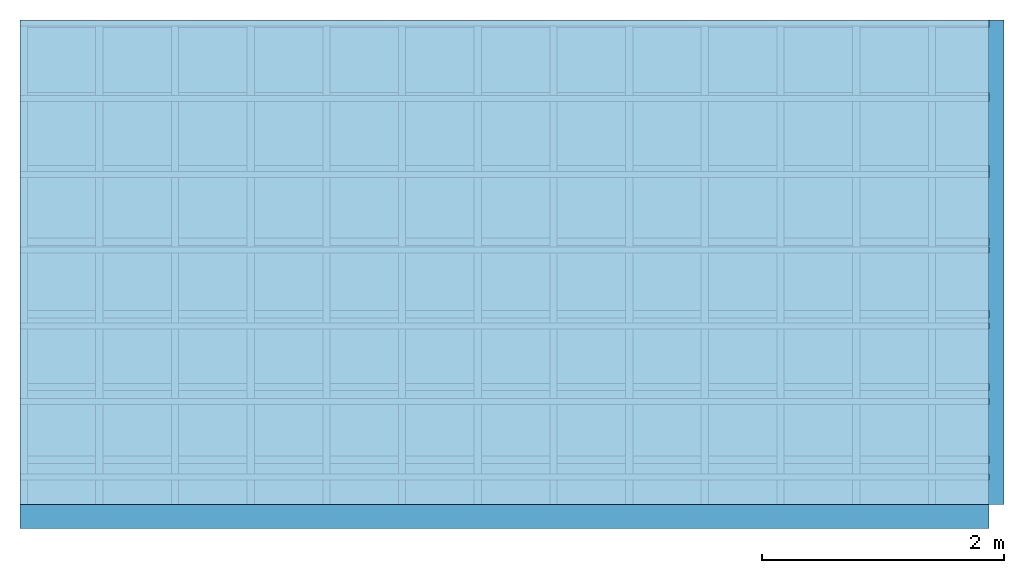
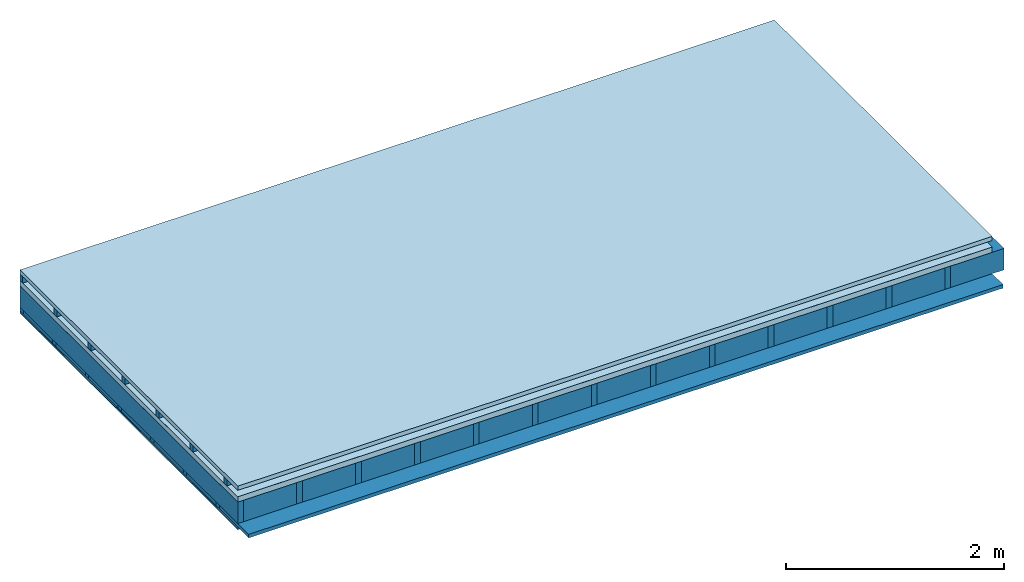
# One storey: 5 members, 5 plates, 1 element without a shape of its own.
"""IFC4 building model written with IfcOpenShell, lengths in metres."""

from ifc_helpers import new_model, si_unit, derived_unit, direction, frame, frame_2d, origin, origin_with_axes, place, context, project, spatial, rectangle, extrude, material, layer, layer_set, type_object, element, aggregate, save


model = new_model("IFC4")

# Units and contexts
plan_context = context("Plan", 3, precision=1e-05, world=origin(), true_north=direction((0.0, 1.0)))
model_context = context("Model", 3, precision=1e-05, world=origin(), true_north=direction((0.0, 1.0)))
ifc_project = project(units=[si_unit("LENGTHUNIT", "METRE"), derived_unit("SOUNDPRESSUREUNIT", [(si_unit("PRESSUREUNIT", "PASCAL", prefix="MICRO"), 0)]), si_unit("ENERGYUNIT", "JOULE", prefix="MEGA"), si_unit("MASSUNIT", "GRAM", prefix="KILO"), derived_unit("THERMALTRANSMITTANCEUNIT", [(si_unit("POWERUNIT", "WATT"), 1), (si_unit("AREAUNIT", "SQUARE_METRE"), -1), (si_unit("THERMODYNAMICTEMPERATUREUNIT", "KELVIN"), -1)]), derived_unit("AREADENSITYUNIT", [(si_unit("MASSUNIT", "GRAM", prefix="KILO"), 1), (si_unit("AREAUNIT", "SQUARE_METRE"), -1)]), derived_unit("USERDEFINED", [(si_unit("ENERGYUNIT", "JOULE", prefix="MEGA"), 1), (si_unit("AREAUNIT", "SQUARE_METRE"), -1)])], contexts=[plan_context, model_context])

# Site, building, storey
site = spatial("IfcSite", under=ifc_project)
building_placement = place(None, origin())
building = spatial("IfcBuilding", under=site, at=building_placement)
storey_placement = place(building_placement, origin())
storey = spatial("IfcBuildingStorey", under=building, at=storey_placement)

# Slab, members, plates
ifc_material_1 = material(Name="Roof tiles", Category="03.015")
ifc_layer_1 = layer(ifc_material_1, 0.047, Name="Roofing")
ifc_layer_2 = layer(None, 0.072, Name="Battens / profiles")
ifc_material_2 = material(Name="Roofing underlay", Category="09.008")
ifc_layer_3 = layer(ifc_material_2, 0.00018, Name="Under the roof")
ifc_material_3 = material(Category="10.009")
ifc_layer_4 = layer(ifc_material_3, 0.06, Name="Exterior insulation layer 1")
ifc_material_4 = material(Name="no composite action")
ifc_layer_5 = layer(ifc_material_4, 0.0, Name="Bond")
ifc_layer_6 = layer(None, 0.24, Name="Supporting structure")
ifc_material_5 = material(Name="of the art")
ifc_layer_7 = layer(ifc_material_5, 0.0, Name="Bond")
ifc_layer_8 = layer(None, 0.04, Name="Battens / profiles")
ifc_material_6 = material(Name="Plasterboard type A", Category="03.008")
ifc_layer_9 = layer(ifc_material_6, 0.015, Name="Covering below 1st layer")
ifc_layer_10 = layer(ifc_material_6, 0.015, Name="Covering below 2nd layer")
ifc_material_7 = material(Name="joints", Category="04.017")
ifc_layer_11 = layer(ifc_material_7, 0.0, Name="Surface below")
ifc_layer_set = layer_set([ifc_layer_1, ifc_layer_2, ifc_layer_3, ifc_layer_4, ifc_layer_5, ifc_layer_6, ifc_layer_7, ifc_layer_8, ifc_layer_9, ifc_layer_10, ifc_layer_11])
slab_type = type_object("IfcSlabType", Name="E0125", PredefinedType="NOTDEFINED", material=ifc_layer_set)
slab_placement = place(None, frame((0.0, 0.0, 0.0), z_axis=(0.0, 0.0, -1.0), x_axis=(1.0, 0.0, 0.0)))
slab = element("IfcSlab", 1, at=slab_placement, inside=storey, type_object=slab_type, material=ifc_layer_set, Name="Slab #1")
ifc_material_8 = material()
member_1_placement = place(slab_placement, origin())
member_1 = element("IfcMember", 2, at=member_1_placement, material=ifc_material_8, Name="Battens / profiles", context=plan_context, shape_type="SweptSolid", body=[
    extrude(rectangle(XDim=0.05, YDim=0.072, at=frame_2d((0.025, 0.036), x_axis=(1.0, 0.0))), frame((0.0, 0.0, 0.047), z_axis=(1.0, 0.0, 0.0), x_axis=(0.0, 1.0, 0.0)), (0.0, 0.0, 1.0), 8.0),
    extrude(rectangle(XDim=0.05, YDim=0.072, at=frame_2d((0.025, 0.036), x_axis=(1.0, 0.0))), frame((0.0, 0.625, 0.047), z_axis=(1.0, 0.0, 0.0), x_axis=(0.0, 1.0, 0.0)), (0.0, 0.0, 1.0), 8.0),
    extrude(rectangle(XDim=0.05, YDim=0.072, at=frame_2d((0.025, 0.036), x_axis=(1.0, 0.0))), frame((0.0, 1.25, 0.047), z_axis=(1.0, 0.0, 0.0), x_axis=(0.0, 1.0, 0.0)), (0.0, 0.0, 1.0), 8.0),
    extrude(rectangle(XDim=0.05, YDim=0.072, at=frame_2d((0.025, 0.036), x_axis=(1.0, 0.0))), frame((0.0, 1.875, 0.047), z_axis=(1.0, 0.0, 0.0), x_axis=(0.0, 1.0, 0.0)), (0.0, 0.0, 1.0), 8.0),
    extrude(rectangle(XDim=0.05, YDim=0.072, at=frame_2d((0.025, 0.036), x_axis=(1.0, 0.0))), frame((0.0, 2.5, 0.047), z_axis=(1.0, 0.0, 0.0), x_axis=(0.0, 1.0, 0.0)), (0.0, 0.0, 1.0), 8.0),
    extrude(rectangle(XDim=0.05, YDim=0.072, at=frame_2d((0.025, 0.036), x_axis=(1.0, 0.0))), frame((0.0, 3.125, 0.047), z_axis=(1.0, 0.0, 0.0), x_axis=(0.0, 1.0, 0.0)), (0.0, 0.0, 1.0), 8.0),
    extrude(rectangle(XDim=0.05, YDim=0.072, at=frame_2d((0.025, 0.036), x_axis=(1.0, 0.0))), frame((0.0, 3.75, 0.047), z_axis=(1.0, 0.0, 0.0), x_axis=(0.0, 1.0, 0.0)), (0.0, 0.0, 1.0), 8.0),
])
ifc_material_9 = material()
member_2_placement = place(slab_placement, origin())
member_2 = element("IfcMember", 3, at=member_2_placement, material=ifc_material_9, Name="Supporting structure", context=plan_context, shape_type="SweptSolid", body=[
    extrude(rectangle(XDim=0.06, YDim=0.24, at=frame_2d((0.03, 0.12), x_axis=(1.0, 0.0))), frame((0.0, 4.0, 0.17918), z_axis=(0.0, -1.0, 0.0), x_axis=(1.0, 0.0, 0.0)), (0.0, 0.0, 1.0), 4.0),
    extrude(rectangle(XDim=0.06, YDim=0.24, at=frame_2d((0.03, 0.12), x_axis=(1.0, 0.0))), frame((0.625, 4.0, 0.17918), z_axis=(0.0, -1.0, 0.0), x_axis=(1.0, 0.0, 0.0)), (0.0, 0.0, 1.0), 4.0),
    extrude(rectangle(XDim=0.06, YDim=0.24, at=frame_2d((0.03, 0.12), x_axis=(1.0, 0.0))), frame((1.25, 4.0, 0.17918), z_axis=(0.0, -1.0, 0.0), x_axis=(1.0, 0.0, 0.0)), (0.0, 0.0, 1.0), 4.0),
    extrude(rectangle(XDim=0.06, YDim=0.24, at=frame_2d((0.03, 0.12), x_axis=(1.0, 0.0))), frame((1.875, 4.0, 0.17918), z_axis=(0.0, -1.0, 0.0), x_axis=(1.0, 0.0, 0.0)), (0.0, 0.0, 1.0), 4.0),
    extrude(rectangle(XDim=0.06, YDim=0.24, at=frame_2d((0.03, 0.12), x_axis=(1.0, 0.0))), frame((2.5, 4.0, 0.17918), z_axis=(0.0, -1.0, 0.0), x_axis=(1.0, 0.0, 0.0)), (0.0, 0.0, 1.0), 4.0),
    extrude(rectangle(XDim=0.06, YDim=0.24, at=frame_2d((0.03, 0.12), x_axis=(1.0, 0.0))), frame((3.125, 4.0, 0.17918), z_axis=(0.0, -1.0, 0.0), x_axis=(1.0, 0.0, 0.0)), (0.0, 0.0, 1.0), 4.0),
    extrude(rectangle(XDim=0.06, YDim=0.24, at=frame_2d((0.03, 0.12), x_axis=(1.0, 0.0))), frame((3.75, 4.0, 0.17918), z_axis=(0.0, -1.0, 0.0), x_axis=(1.0, 0.0, 0.0)), (0.0, 0.0, 1.0), 4.0),
    extrude(rectangle(XDim=0.06, YDim=0.24, at=frame_2d((0.03, 0.12), x_axis=(1.0, 0.0))), frame((4.375, 4.0, 0.17918), z_axis=(0.0, -1.0, 0.0), x_axis=(1.0, 0.0, 0.0)), (0.0, 0.0, 1.0), 4.0),
    extrude(rectangle(XDim=0.06, YDim=0.24, at=frame_2d((0.03, 0.12), x_axis=(1.0, 0.0))), frame((5.0, 4.0, 0.17918), z_axis=(0.0, -1.0, 0.0), x_axis=(1.0, 0.0, 0.0)), (0.0, 0.0, 1.0), 4.0),
    extrude(rectangle(XDim=0.06, YDim=0.24, at=frame_2d((0.03, 0.12), x_axis=(1.0, 0.0))), frame((5.625, 4.0, 0.17918), z_axis=(0.0, -1.0, 0.0), x_axis=(1.0, 0.0, 0.0)), (0.0, 0.0, 1.0), 4.0),
    extrude(rectangle(XDim=0.06, YDim=0.24, at=frame_2d((0.03, 0.12), x_axis=(1.0, 0.0))), frame((6.25, 4.0, 0.17918), z_axis=(0.0, -1.0, 0.0), x_axis=(1.0, 0.0, 0.0)), (0.0, 0.0, 1.0), 4.0),
    extrude(rectangle(XDim=0.06, YDim=0.24, at=frame_2d((0.03, 0.12), x_axis=(1.0, 0.0))), frame((6.875, 4.0, 0.17918), z_axis=(0.0, -1.0, 0.0), x_axis=(1.0, 0.0, 0.0)), (0.0, 0.0, 1.0), 4.0),
    extrude(rectangle(XDim=0.06, YDim=0.24, at=frame_2d((0.03, 0.12), x_axis=(1.0, 0.0))), frame((7.5, 4.0, 0.17918), z_axis=(0.0, -1.0, 0.0), x_axis=(1.0, 0.0, 0.0)), (0.0, 0.0, 1.0), 4.0),
])
ifc_material_10 = material()
member_3_placement = place(slab_placement, origin())
member_3 = element("IfcMember", 4, at=member_3_placement, material=ifc_material_10, Name="Cavity", context=plan_context, shape_type="SweptSolid", body=[
    extrude(rectangle(XDim=0.565, YDim=0.24, at=frame_2d((0.2825, 0.12), x_axis=(1.0, 0.0))), frame((0.06, 4.0, 0.17918), z_axis=(0.0, -1.0, 0.0), x_axis=(1.0, 0.0, 0.0)), (0.0, 0.0, 1.0), 4.0),
    extrude(rectangle(XDim=0.565, YDim=0.24, at=frame_2d((0.2825, 0.12), x_axis=(1.0, 0.0))), frame((0.685, 4.0, 0.17918), z_axis=(0.0, -1.0, 0.0), x_axis=(1.0, 0.0, 0.0)), (0.0, 0.0, 1.0), 4.0),
    extrude(rectangle(XDim=0.565, YDim=0.24, at=frame_2d((0.2825, 0.12), x_axis=(1.0, 0.0))), frame((1.31, 4.0, 0.17918), z_axis=(0.0, -1.0, 0.0), x_axis=(1.0, 0.0, 0.0)), (0.0, 0.0, 1.0), 4.0),
    extrude(rectangle(XDim=0.565, YDim=0.24, at=frame_2d((0.2825, 0.12), x_axis=(1.0, 0.0))), frame((1.935, 4.0, 0.17918), z_axis=(0.0, -1.0, 0.0), x_axis=(1.0, 0.0, 0.0)), (0.0, 0.0, 1.0), 4.0),
    extrude(rectangle(XDim=0.565, YDim=0.24, at=frame_2d((0.2825, 0.12), x_axis=(1.0, 0.0))), frame((2.56, 4.0, 0.17918), z_axis=(0.0, -1.0, 0.0), x_axis=(1.0, 0.0, 0.0)), (0.0, 0.0, 1.0), 4.0),
    extrude(rectangle(XDim=0.565, YDim=0.24, at=frame_2d((0.2825, 0.12), x_axis=(1.0, 0.0))), frame((3.185, 4.0, 0.17918), z_axis=(0.0, -1.0, 0.0), x_axis=(1.0, 0.0, 0.0)), (0.0, 0.0, 1.0), 4.0),
    extrude(rectangle(XDim=0.565, YDim=0.24, at=frame_2d((0.2825, 0.12), x_axis=(1.0, 0.0))), frame((3.81, 4.0, 0.17918), z_axis=(0.0, -1.0, 0.0), x_axis=(1.0, 0.0, 0.0)), (0.0, 0.0, 1.0), 4.0),
    extrude(rectangle(XDim=0.565, YDim=0.24, at=frame_2d((0.2825, 0.12), x_axis=(1.0, 0.0))), frame((4.435, 4.0, 0.17918), z_axis=(0.0, -1.0, 0.0), x_axis=(1.0, 0.0, 0.0)), (0.0, 0.0, 1.0), 4.0),
    extrude(rectangle(XDim=0.565, YDim=0.24, at=frame_2d((0.2825, 0.12), x_axis=(1.0, 0.0))), frame((5.06, 4.0, 0.17918), z_axis=(0.0, -1.0, 0.0), x_axis=(1.0, 0.0, 0.0)), (0.0, 0.0, 1.0), 4.0),
    extrude(rectangle(XDim=0.565, YDim=0.24, at=frame_2d((0.2825, 0.12), x_axis=(1.0, 0.0))), frame((5.685, 4.0, 0.17918), z_axis=(0.0, -1.0, 0.0), x_axis=(1.0, 0.0, 0.0)), (0.0, 0.0, 1.0), 4.0),
    extrude(rectangle(XDim=0.565, YDim=0.24, at=frame_2d((0.2825, 0.12), x_axis=(1.0, 0.0))), frame((6.31, 4.0, 0.17918), z_axis=(0.0, -1.0, 0.0), x_axis=(1.0, 0.0, 0.0)), (0.0, 0.0, 1.0), 4.0),
    extrude(rectangle(XDim=0.565, YDim=0.24, at=frame_2d((0.2825, 0.12), x_axis=(1.0, 0.0))), frame((6.935, 4.0, 0.17918), z_axis=(0.0, -1.0, 0.0), x_axis=(1.0, 0.0, 0.0)), (0.0, 0.0, 1.0), 4.0),
    extrude(rectangle(XDim=0.565, YDim=0.24, at=frame_2d((0.2825, 0.12), x_axis=(1.0, 0.0))), frame((7.56, 4.0, 0.17918), z_axis=(0.0, -1.0, 0.0), x_axis=(1.0, 0.0, 0.0)), (0.0, 0.0, 1.0), 4.0),
])
ifc_material_11 = material()
member_4_placement = place(slab_placement, origin())
member_4 = element("IfcMember", 5, at=member_4_placement, material=ifc_material_11, Name="Battens / profiles", context=plan_context, shape_type="SweptSolid", body=[
    extrude(rectangle(XDim=0.06, YDim=0.04, at=frame_2d((0.03, 0.02), x_axis=(1.0, 0.0))), frame((0.0, 0.0, 0.41918), z_axis=(1.0, 0.0, 0.0), x_axis=(0.0, 1.0, 0.0)), (0.0, 0.0, 1.0), 8.0),
    extrude(rectangle(XDim=0.06, YDim=0.04, at=frame_2d((0.03, 0.02), x_axis=(1.0, 0.0))), frame((0.0, 0.6, 0.41918), z_axis=(1.0, 0.0, 0.0), x_axis=(0.0, 1.0, 0.0)), (0.0, 0.0, 1.0), 8.0),
    extrude(rectangle(XDim=0.06, YDim=0.04, at=frame_2d((0.03, 0.02), x_axis=(1.0, 0.0))), frame((0.0, 1.2, 0.41918), z_axis=(1.0, 0.0, 0.0), x_axis=(0.0, 1.0, 0.0)), (0.0, 0.0, 1.0), 8.0),
    extrude(rectangle(XDim=0.06, YDim=0.04, at=frame_2d((0.03, 0.02), x_axis=(1.0, 0.0))), frame((0.0, 1.8, 0.41918), z_axis=(1.0, 0.0, 0.0), x_axis=(0.0, 1.0, 0.0)), (0.0, 0.0, 1.0), 8.0),
    extrude(rectangle(XDim=0.06, YDim=0.04, at=frame_2d((0.03, 0.02), x_axis=(1.0, 0.0))), frame((0.0, 2.4, 0.41918), z_axis=(1.0, 0.0, 0.0), x_axis=(0.0, 1.0, 0.0)), (0.0, 0.0, 1.0), 8.0),
    extrude(rectangle(XDim=0.06, YDim=0.04, at=frame_2d((0.03, 0.02), x_axis=(1.0, 0.0))), frame((0.0, 3.0, 0.41918), z_axis=(1.0, 0.0, 0.0), x_axis=(0.0, 1.0, 0.0)), (0.0, 0.0, 1.0), 8.0),
    extrude(rectangle(XDim=0.06, YDim=0.04, at=frame_2d((0.03, 0.02), x_axis=(1.0, 0.0))), frame((0.0, 3.6, 0.41918), z_axis=(1.0, 0.0, 0.0), x_axis=(0.0, 1.0, 0.0)), (0.0, 0.0, 1.0), 8.0),
])
ifc_material_12 = material(Name="Mineral wool")
member_5_placement = place(slab_placement, origin())
member_5 = element("IfcMember", 6, at=member_5_placement, material=ifc_material_12, Name="Cavity", context=plan_context, shape_type="SweptSolid", body=[
    extrude(rectangle(XDim=0.54, YDim=0.04, at=frame_2d((0.27, 0.02), x_axis=(1.0, 0.0))), frame((0.0, 0.06, 0.41918), z_axis=(1.0, 0.0, 0.0), x_axis=(0.0, 1.0, 0.0)), (0.0, 0.0, 1.0), 8.0),
    extrude(rectangle(XDim=0.54, YDim=0.04, at=frame_2d((0.27, 0.02), x_axis=(1.0, 0.0))), frame((0.0, 0.66, 0.41918), z_axis=(1.0, 0.0, 0.0), x_axis=(0.0, 1.0, 0.0)), (0.0, 0.0, 1.0), 8.0),
    extrude(rectangle(XDim=0.54, YDim=0.04, at=frame_2d((0.27, 0.02), x_axis=(1.0, 0.0))), frame((0.0, 1.26, 0.41918), z_axis=(1.0, 0.0, 0.0), x_axis=(0.0, 1.0, 0.0)), (0.0, 0.0, 1.0), 8.0),
    extrude(rectangle(XDim=0.54, YDim=0.04, at=frame_2d((0.27, 0.02), x_axis=(1.0, 0.0))), frame((0.0, 1.86, 0.41918), z_axis=(1.0, 0.0, 0.0), x_axis=(0.0, 1.0, 0.0)), (0.0, 0.0, 1.0), 8.0),
    extrude(rectangle(XDim=0.54, YDim=0.04, at=frame_2d((0.27, 0.02), x_axis=(1.0, 0.0))), frame((0.0, 2.46, 0.41918), z_axis=(1.0, 0.0, 0.0), x_axis=(0.0, 1.0, 0.0)), (0.0, 0.0, 1.0), 8.0),
    extrude(rectangle(XDim=0.54, YDim=0.04, at=frame_2d((0.27, 0.02), x_axis=(1.0, 0.0))), frame((0.0, 3.06, 0.41918), z_axis=(1.0, 0.0, 0.0), x_axis=(0.0, 1.0, 0.0)), (0.0, 0.0, 1.0), 8.0),
    extrude(rectangle(XDim=0.54, YDim=0.04, at=frame_2d((0.27, 0.02), x_axis=(1.0, 0.0))), frame((0.0, 3.66, 0.41918), z_axis=(1.0, 0.0, 0.0), x_axis=(0.0, 1.0, 0.0)), (0.0, 0.0, 1.0), 8.0),
])
plate_1_placement = place(slab_placement, origin())
plate_1 = element("IfcPlate", 7, at=plate_1_placement, material=ifc_material_1, Name="Roofing", context=plan_context, shape_type="SweptSolid", body=[
    extrude(rectangle(XDim=8.0, YDim=4.0, at=frame_2d((4.0, 2.0), x_axis=(1.0, 0.0))), origin_with_axes(), (0.0, 0.0, 1.0), 0.047),
])
plate_2_placement = place(slab_placement, origin())
plate_2 = element("IfcPlate", 8, at=plate_2_placement, material=ifc_material_2, Name="Under the roof", context=plan_context, shape_type="SweptSolid", body=[
    extrude(rectangle(XDim=8.0, YDim=4.0, at=frame_2d((4.0, 2.0), x_axis=(1.0, 0.0))), frame((0.0, 0.0, 0.119), z_axis=(0.0, 0.0, 1.0), x_axis=(1.0, 0.0, 0.0)), (0.0, 0.0, 1.0), 0.00018),
])
plate_3_placement = place(slab_placement, origin())
plate_3 = element("IfcPlate", 9, at=plate_3_placement, material=ifc_material_3, Name="Exterior insulation layer 1", context=plan_context, shape_type="SweptSolid", body=[
    extrude(rectangle(XDim=8.0, YDim=4.0, at=frame_2d((4.0, 2.0), x_axis=(1.0, 0.0))), frame((0.0, 0.0, 0.11918), z_axis=(0.0, 0.0, 1.0), x_axis=(1.0, 0.0, 0.0)), (0.0, 0.0, 1.0), 0.06),
])
plate_4_placement = place(slab_placement, origin())
plate_4 = element("IfcPlate", 10, at=plate_4_placement, material=ifc_material_6, Name="Covering below 1st layer", context=plan_context, shape_type="SweptSolid", body=[
    extrude(rectangle(XDim=8.0, YDim=4.0, at=frame_2d((4.0, 2.0), x_axis=(1.0, 0.0))), frame((0.0, 0.0, 0.45918), z_axis=(0.0, 0.0, 1.0), x_axis=(1.0, 0.0, 0.0)), (0.0, 0.0, 1.0), 0.015),
])
plate_5_placement = place(slab_placement, origin())
plate_5 = element("IfcPlate", 11, at=plate_5_placement, material=ifc_material_6, Name="Covering below 2nd layer", context=plan_context, shape_type="SweptSolid", body=[
    extrude(rectangle(XDim=8.0, YDim=4.0, at=frame_2d((4.0, 2.0), x_axis=(1.0, 0.0))), frame((0.0, 0.0, 0.47418), z_axis=(0.0, 0.0, 1.0), x_axis=(1.0, 0.0, 0.0)), (0.0, 0.0, 1.0), 0.015),
])
aggregate(slab, [plate_1, member_1, plate_2, plate_3, member_2, member_3, member_4, member_5, plate_4, plate_5])

save(model, "model.ifc")
